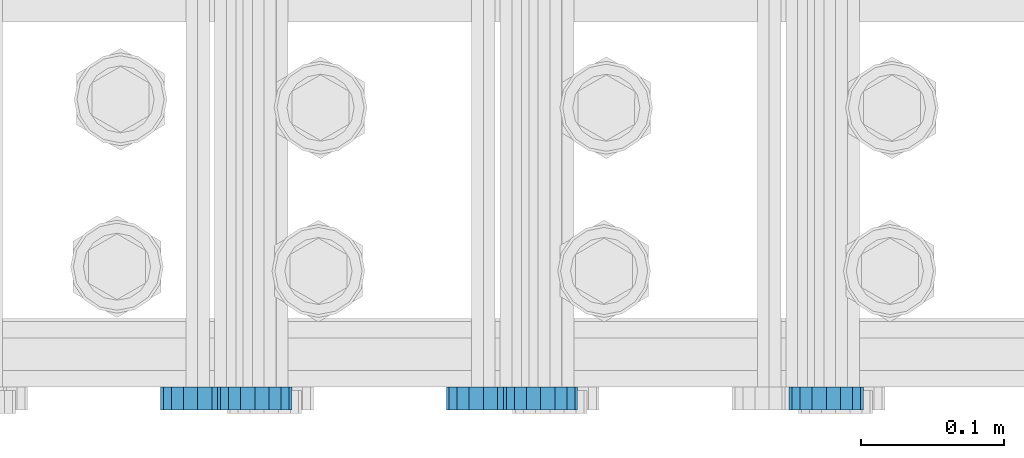
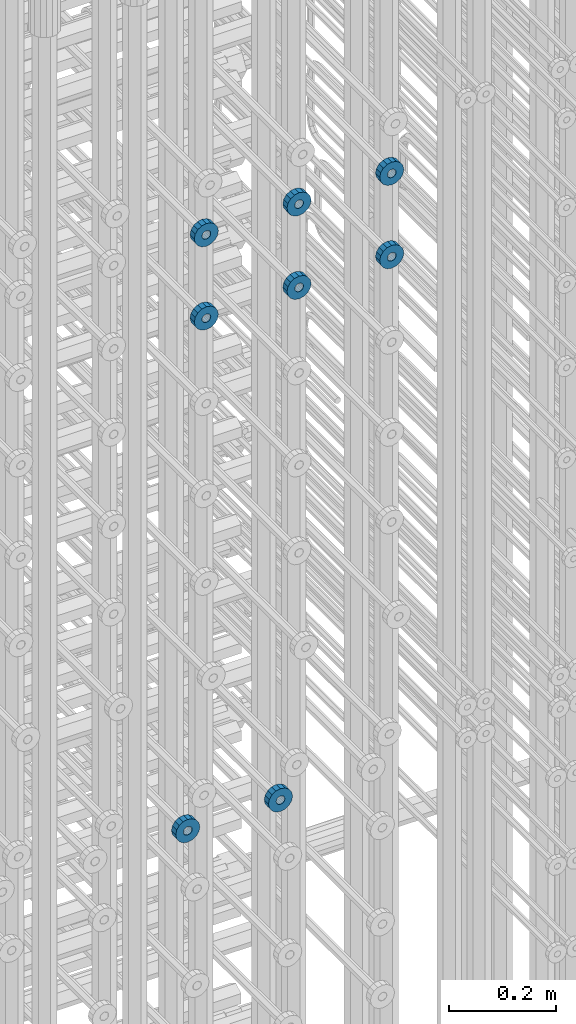
# One storey, part 123 of 177: 8 beams.
"""IFC2X3 building model written with IfcOpenShell, lengths in millimetres."""

from ifc_helpers import new_model, si_unit, frame, origin_with_axes, place, context, subcontext, project, spatial, faceted_brep, material, type_object, element, save


model = new_model("IFC2X3")

# Units and contexts
model_context_1 = context("Model", 3, precision=1e-05, world=origin_with_axes())
model_context_2 = context("Model", 3, precision=1e-05, world=origin_with_axes())
body_context = subcontext(model_context_2, "Body", "Model", "MODEL_VIEW")
ifc_project = project(units=[si_unit("LENGTHUNIT", "METRE", prefix="MILLI"), si_unit("AREAUNIT", "SQUARE_METRE"), si_unit("VOLUMEUNIT", "CUBIC_METRE"), si_unit("MASSUNIT", "GRAM", prefix="KILO"), si_unit("TIMEUNIT", "SECOND"), si_unit("PLANEANGLEUNIT", "RADIAN"), si_unit("SOLIDANGLEUNIT", "STERADIAN"), si_unit("THERMODYNAMICTEMPERATUREUNIT", "DEGREE_CELSIUS"), si_unit("LUMINOUSINTENSITYUNIT", "LUMEN")], contexts=[model_context_1])

# Site, building, storey
site_placement = place(None, origin_with_axes())
site = spatial("IfcSite", under=ifc_project, at=site_placement, CompositionType="ELEMENT")
building_placement = place(site_placement, origin_with_axes())
building = spatial("IfcBuilding", under=site, at=building_placement, Name="Undefined", CompositionType="ELEMENT")
storey_placement = place(building_placement, origin_with_axes())
storey = spatial("IfcBuildingStorey", under=building, at=storey_placement, Name="Undefined", CompositionType="ELEMENT", Elevation=0.0)

# Beams
ifc_material = material(Name="STEEL/Steel_Undefined")
beam_type = type_object("IfcBeamType", PredefinedType="NOTDEFINED")
beam_1_placement = place(storey_placement, frame((2031089.49847313, 6205075.98588033, 20799.986811442), z_axis=(0.0, 0.0, -1.0), x_axis=(0.0, -1.0, 0.0)))
element("IfcBeam", 1, at=beam_1_placement, inside=storey, type_object=beam_type, material=ifc_material, context=body_context, shape_type="Brep", body=[
    faceted_brep([(0.0, -9.5, 0.0), (0.0, -8.77685555908829, 3.63549260746731), (16.0, -8.77685555908829, 3.63549260746731), (16.0, -9.5, 0.0), (0.0, -6.71751442085952, 6.71751442127061), (16.0, -6.71751442085952, 6.71751442127061), (0.0, -3.63549260701984, 8.77685555885546), (16.0, -3.63549260701984, 8.77685555885546), (-2.02452244836415e-12, 0.0, 9.5), (16.0, 0.0, 9.5), (0.0, 3.63549260701984, 8.77685555885546), (16.0, 3.63549260701984, 8.77685555885546), (0.0, 6.71751442085952, 6.71751442127061), (16.0, 6.71751442085952, 6.71751442127061), (0.0, 8.77685555908829, 3.63549260746731), (16.0, 8.77685555908829, 3.63549260746731), (0.0, 9.5, 0.0), (16.0, 9.5, 0.0), (0.0, 8.77685555908829, -3.63549260746731), (16.0, 8.77685555908829, -3.63549260746731), (0.0, 6.71751442085952, -6.71751442127061), (16.0, 6.71751442085952, -6.71751442127061), (0.0, 3.63549260701984, -8.77685555885546), (16.0, 3.63549260701984, -8.77685555885546), (2.02452244836415e-12, -3.69149155687865e-15, -9.5), (16.0, 0.0, -9.5), (0.0, -3.63549260701984, -8.77685555885546), (16.0, -3.63549260701984, -8.77685555885546), (0.0, -6.71751442085952, -6.71751442127061), (16.0, -6.71751442085952, -6.71751442127061), (0.0, -8.77685555908829, -3.63549260746731), (16.0, -8.77685555908829, -3.63549260746731), (0.0, -26.0, 0.0), (0.0, -24.0208678450435, -9.94976924149159), (16.0, -24.0208678450435, -9.94976924149159), (16.0, -26.0, 0.0), (0.0, -18.3847763109952, -18.3847763108497), (16.0, -18.3847763109952, -18.3847763108497), (0.0, -9.94976924173534, -24.0208678452946), (16.0, -9.94976924173534, -24.0208678452946), (0.0, 0.0, -26.0), (16.0, 0.0, -26.0), (0.0, 9.94976924173534, -24.0208678452946), (16.0, 9.94976924173534, -24.0208678452946), (0.0, 18.3847763109952, -18.3847763108497), (16.0, 18.3847763109952, -18.3847763108497), (0.0, 24.0208678450435, -9.94976924149159), (16.0, 24.0208678450435, -9.94976924149159), (0.0, 26.0, 0.0), (16.0, 26.0, 0.0), (0.0, 24.0208678450435, 9.94976924149159), (16.0, 24.0208678450435, 9.94976924149159), (0.0, 18.3847763109952, 18.3847763108497), (16.0, 18.3847763109952, 18.3847763108497), (0.0, 9.94976924173534, 24.0208678452946), (16.0, 9.94976924173534, 24.0208678452946), (0.0, 0.0, 26.0), (16.0, 0.0, 26.0), (0.0, -9.94976924173534, 24.0208678452946), (16.0, -9.94976924173534, 24.0208678452946), (0.0, -18.3847763109952, 18.3847763108497), (16.0, -18.3847763109952, 18.3847763108497), (0.0, -24.0208678450435, 9.94976924149159), (16.0, -24.0208678450435, 9.94976924149159)], [[[0, 1, 2, 3]], [[1, 4, 5, 2]], [[4, 6, 7, 5]], [[6, 8, 9, 7]], [[8, 10, 11, 9]], [[10, 12, 13, 11]], [[12, 14, 15, 13]], [[14, 16, 17, 15]], [[16, 18, 19, 17]], [[18, 20, 21, 19]], [[20, 22, 23, 21]], [[22, 24, 25, 23]], [[24, 26, 27, 25]], [[26, 28, 29, 27]], [[28, 30, 31, 29]], [[30, 0, 3, 31]], [[32, 33, 34, 35]], [[33, 36, 37, 34]], [[36, 38, 39, 37]], [[38, 40, 41, 39]], [[40, 42, 43, 41]], [[42, 44, 45, 43]], [[44, 46, 47, 45]], [[46, 48, 49, 47]], [[48, 50, 51, 49]], [[50, 52, 53, 51]], [[52, 54, 55, 53]], [[54, 56, 57, 55]], [[56, 58, 59, 57]], [[58, 60, 61, 59]], [[60, 62, 63, 61]], [[62, 32, 35, 63]], [[37, 39, 41, 43, 45, 47, 49, 51, 53, 55, 57, 59, 61, 63, 35, 34], [5, 7, 9, 11, 13, 15, 17, 19, 21, 23, 25, 27, 29, 31, 3, 2]], [[62, 60, 58, 56, 54, 52, 50, 48, 46, 44, 42, 40, 38, 36, 33, 32], [30, 28, 26, 24, 22, 20, 18, 16, 14, 12, 10, 8, 6, 4, 1, 0]]]),
])
beam_2_placement = place(storey_placement, frame((2030889.49847313, 6205075.98588033, 20799.986811442), z_axis=(0.0, 0.0, -1.0), x_axis=(0.0, -1.0, 0.0)))
element("IfcBeam", 2, at=beam_2_placement, inside=storey, type_object=beam_type, material=ifc_material, context=body_context, shape_type="Brep", body=[
    faceted_brep([(0.0, -9.5, 0.0), (0.0, -8.77685555908829, 3.63549260746731), (16.0, -8.77685555908829, 3.63549260746731), (16.0, -9.5, 0.0), (0.0, -6.71751442085952, 6.71751442127061), (16.0, -6.71751442085952, 6.71751442127061), (0.0, -3.63549260701984, 8.77685555885546), (16.0, -3.63549260701984, 8.77685555885546), (-2.02452244836415e-12, 0.0, 9.5), (16.0, 0.0, 9.5), (0.0, 3.63549260701984, 8.77685555885546), (16.0, 3.63549260701984, 8.77685555885546), (0.0, 6.71751442085952, 6.71751442127061), (16.0, 6.71751442085952, 6.71751442127061), (0.0, 8.77685555908829, 3.63549260746731), (16.0, 8.77685555908829, 3.63549260746731), (0.0, 9.5, 0.0), (16.0, 9.5, 0.0), (0.0, 8.77685555908829, -3.63549260746731), (16.0, 8.77685555908829, -3.63549260746731), (0.0, 6.71751442085952, -6.71751442127061), (16.0, 6.71751442085952, -6.71751442127061), (0.0, 3.63549260701984, -8.77685555885546), (16.0, 3.63549260701984, -8.77685555885546), (2.02452244836415e-12, -3.69149155687865e-15, -9.5), (16.0, 0.0, -9.5), (0.0, -3.63549260701984, -8.77685555885546), (16.0, -3.63549260701984, -8.77685555885546), (0.0, -6.71751442085952, -6.71751442127061), (16.0, -6.71751442085952, -6.71751442127061), (0.0, -8.77685555908829, -3.63549260746731), (16.0, -8.77685555908829, -3.63549260746731), (0.0, -26.0, 0.0), (0.0, -24.0208678450435, -9.94976924149159), (16.0, -24.0208678450435, -9.94976924149159), (16.0, -26.0, 0.0), (0.0, -18.3847763109952, -18.3847763108497), (16.0, -18.3847763109952, -18.3847763108497), (0.0, -9.94976924173534, -24.0208678452946), (16.0, -9.94976924173534, -24.0208678452946), (0.0, 0.0, -26.0), (16.0, 0.0, -26.0), (0.0, 9.94976924173534, -24.0208678452946), (16.0, 9.94976924173534, -24.0208678452946), (0.0, 18.3847763109952, -18.3847763108497), (16.0, 18.3847763109952, -18.3847763108497), (0.0, 24.0208678450435, -9.94976924149159), (16.0, 24.0208678450435, -9.94976924149159), (0.0, 26.0, 0.0), (16.0, 26.0, 0.0), (0.0, 24.0208678450435, 9.94976924149159), (16.0, 24.0208678450435, 9.94976924149159), (0.0, 18.3847763109952, 18.3847763108497), (16.0, 18.3847763109952, 18.3847763108497), (0.0, 9.94976924173534, 24.0208678452946), (16.0, 9.94976924173534, 24.0208678452946), (0.0, 0.0, 26.0), (16.0, 0.0, 26.0), (0.0, -9.94976924173534, 24.0208678452946), (16.0, -9.94976924173534, 24.0208678452946), (0.0, -18.3847763109952, 18.3847763108497), (16.0, -18.3847763109952, 18.3847763108497), (0.0, -24.0208678450435, 9.94976924149159), (16.0, -24.0208678450435, 9.94976924149159)], [[[0, 1, 2, 3]], [[1, 4, 5, 2]], [[4, 6, 7, 5]], [[6, 8, 9, 7]], [[8, 10, 11, 9]], [[10, 12, 13, 11]], [[12, 14, 15, 13]], [[14, 16, 17, 15]], [[16, 18, 19, 17]], [[18, 20, 21, 19]], [[20, 22, 23, 21]], [[22, 24, 25, 23]], [[24, 26, 27, 25]], [[26, 28, 29, 27]], [[28, 30, 31, 29]], [[30, 0, 3, 31]], [[32, 33, 34, 35]], [[33, 36, 37, 34]], [[36, 38, 39, 37]], [[38, 40, 41, 39]], [[40, 42, 43, 41]], [[42, 44, 45, 43]], [[44, 46, 47, 45]], [[46, 48, 49, 47]], [[48, 50, 51, 49]], [[50, 52, 53, 51]], [[52, 54, 55, 53]], [[54, 56, 57, 55]], [[56, 58, 59, 57]], [[58, 60, 61, 59]], [[60, 62, 63, 61]], [[62, 32, 35, 63]], [[37, 39, 41, 43, 45, 47, 49, 51, 53, 55, 57, 59, 61, 63, 35, 34], [5, 7, 9, 11, 13, 15, 17, 19, 21, 23, 25, 27, 29, 31, 3, 2]], [[62, 60, 58, 56, 54, 52, 50, 48, 46, 44, 42, 40, 38, 36, 33, 32], [30, 28, 26, 24, 22, 20, 18, 16, 14, 12, 10, 8, 6, 4, 1, 0]]]),
])
beam_3_placement = place(storey_placement, frame((2031329.49847313, 6205075.98588636, 22144.9868126721), z_axis=(0.0, 0.0, -1.0), x_axis=(0.0, -1.0, 0.0)))
element("IfcBeam", 3, at=beam_3_placement, inside=storey, type_object=beam_type, material=ifc_material, context=body_context, shape_type="Brep", body=[
    faceted_brep([(0.0, -9.5, 0.0), (0.0, -8.77685555908829, 3.63549260746731), (16.0, -8.77685555908829, 3.63549260746731), (16.0, -9.5, 0.0), (0.0, -6.71751442085952, 6.71751442127061), (16.0, -6.71751442085952, 6.71751442127061), (0.0, -3.63549260701984, 8.77685555885546), (16.0, -3.63549260701984, 8.77685555885546), (-2.02452244836415e-12, 0.0, 9.5), (16.0, 0.0, 9.5), (0.0, 3.63549260701984, 8.77685555885546), (16.0, 3.63549260701984, 8.77685555885546), (0.0, 6.71751442085952, 6.71751442127061), (16.0, 6.71751442085952, 6.71751442127061), (0.0, 8.77685555908829, 3.63549260746731), (16.0, 8.77685555908829, 3.63549260746731), (0.0, 9.5, 0.0), (16.0, 9.5, 0.0), (0.0, 8.77685555908829, -3.63549260746731), (16.0, 8.77685555908829, -3.63549260746731), (0.0, 6.71751442085952, -6.71751442127061), (16.0, 6.71751442085952, -6.71751442127061), (0.0, 3.63549260701984, -8.77685555885546), (16.0, 3.63549260701984, -8.77685555885546), (2.02452244836415e-12, -3.69149155687865e-15, -9.5), (16.0, 0.0, -9.5), (0.0, -3.63549260701984, -8.77685555885546), (16.0, -3.63549260701984, -8.77685555885546), (0.0, -6.71751442085952, -6.71751442127061), (16.0, -6.71751442085952, -6.71751442127061), (0.0, -8.77685555908829, -3.63549260746731), (16.0, -8.77685555908829, -3.63549260746731), (0.0, -26.0, 0.0), (0.0, -24.0208678450435, -9.94976924149159), (16.0, -24.0208678450435, -9.94976924149159), (16.0, -26.0, 0.0), (0.0, -18.3847763109952, -18.3847763108497), (16.0, -18.3847763109952, -18.3847763108497), (0.0, -9.94976924173534, -24.0208678452946), (16.0, -9.94976924173534, -24.0208678452946), (0.0, 0.0, -26.0), (16.0, 0.0, -26.0), (0.0, 9.94976924173534, -24.0208678452946), (16.0, 9.94976924173534, -24.0208678452946), (0.0, 18.3847763109952, -18.3847763108497), (16.0, 18.3847763109952, -18.3847763108497), (0.0, 24.0208678450435, -9.94976924149159), (16.0, 24.0208678450435, -9.94976924149159), (0.0, 26.0, 0.0), (16.0, 26.0, 0.0), (0.0, 24.0208678450435, 9.94976924149159), (16.0, 24.0208678450435, 9.94976924149159), (0.0, 18.3847763109952, 18.3847763108497), (16.0, 18.3847763109952, 18.3847763108497), (0.0, 9.94976924173534, 24.0208678452946), (16.0, 9.94976924173534, 24.0208678452946), (0.0, 0.0, 26.0), (16.0, 0.0, 26.0), (0.0, -9.94976924173534, 24.0208678452946), (16.0, -9.94976924173534, 24.0208678452946), (0.0, -18.3847763109952, 18.3847763108497), (16.0, -18.3847763109952, 18.3847763108497), (0.0, -24.0208678450435, 9.94976924149159), (16.0, -24.0208678450435, 9.94976924149159)], [[[0, 1, 2, 3]], [[1, 4, 5, 2]], [[4, 6, 7, 5]], [[6, 8, 9, 7]], [[8, 10, 11, 9]], [[10, 12, 13, 11]], [[12, 14, 15, 13]], [[14, 16, 17, 15]], [[16, 18, 19, 17]], [[18, 20, 21, 19]], [[20, 22, 23, 21]], [[22, 24, 25, 23]], [[24, 26, 27, 25]], [[26, 28, 29, 27]], [[28, 30, 31, 29]], [[30, 0, 3, 31]], [[32, 33, 34, 35]], [[33, 36, 37, 34]], [[36, 38, 39, 37]], [[38, 40, 41, 39]], [[40, 42, 43, 41]], [[42, 44, 45, 43]], [[44, 46, 47, 45]], [[46, 48, 49, 47]], [[48, 50, 51, 49]], [[50, 52, 53, 51]], [[52, 54, 55, 53]], [[54, 56, 57, 55]], [[56, 58, 59, 57]], [[58, 60, 61, 59]], [[60, 62, 63, 61]], [[62, 32, 35, 63]], [[37, 39, 41, 43, 45, 47, 49, 51, 53, 55, 57, 59, 61, 63, 35, 34], [5, 7, 9, 11, 13, 15, 17, 19, 21, 23, 25, 27, 29, 31, 3, 2]], [[62, 60, 58, 56, 54, 52, 50, 48, 46, 44, 42, 40, 38, 36, 33, 32], [30, 28, 26, 24, 22, 20, 18, 16, 14, 12, 10, 8, 6, 4, 1, 0]]]),
])
beam_4_placement = place(storey_placement, frame((2031129.49847313, 6205075.98588636, 22144.9868126721), z_axis=(0.0, 0.0, -1.0), x_axis=(0.0, -1.0, 0.0)))
element("IfcBeam", 4, at=beam_4_placement, inside=storey, type_object=beam_type, material=ifc_material, context=body_context, shape_type="Brep", body=[
    faceted_brep([(0.0, -9.5, 0.0), (0.0, -8.77685555908829, 3.63549260746731), (16.0, -8.77685555908829, 3.63549260746731), (16.0, -9.5, 0.0), (0.0, -6.71751442085952, 6.71751442127061), (16.0, -6.71751442085952, 6.71751442127061), (0.0, -3.63549260701984, 8.77685555885546), (16.0, -3.63549260701984, 8.77685555885546), (-2.02452244836415e-12, 0.0, 9.5), (16.0, 0.0, 9.5), (0.0, 3.63549260701984, 8.77685555885546), (16.0, 3.63549260701984, 8.77685555885546), (0.0, 6.71751442085952, 6.71751442127061), (16.0, 6.71751442085952, 6.71751442127061), (0.0, 8.77685555908829, 3.63549260746731), (16.0, 8.77685555908829, 3.63549260746731), (0.0, 9.5, 0.0), (16.0, 9.5, 0.0), (0.0, 8.77685555908829, -3.63549260746731), (16.0, 8.77685555908829, -3.63549260746731), (0.0, 6.71751442085952, -6.71751442127061), (16.0, 6.71751442085952, -6.71751442127061), (0.0, 3.63549260701984, -8.77685555885546), (16.0, 3.63549260701984, -8.77685555885546), (2.02452244836415e-12, -3.69149155687865e-15, -9.5), (16.0, 0.0, -9.5), (0.0, -3.63549260701984, -8.77685555885546), (16.0, -3.63549260701984, -8.77685555885546), (0.0, -6.71751442085952, -6.71751442127061), (16.0, -6.71751442085952, -6.71751442127061), (0.0, -8.77685555908829, -3.63549260746731), (16.0, -8.77685555908829, -3.63549260746731), (0.0, -26.0, 0.0), (0.0, -24.0208678450435, -9.94976924149159), (16.0, -24.0208678450435, -9.94976924149159), (16.0, -26.0, 0.0), (0.0, -18.3847763109952, -18.3847763108497), (16.0, -18.3847763109952, -18.3847763108497), (0.0, -9.94976924173534, -24.0208678452946), (16.0, -9.94976924173534, -24.0208678452946), (0.0, 0.0, -26.0), (16.0, 0.0, -26.0), (0.0, 9.94976924173534, -24.0208678452946), (16.0, 9.94976924173534, -24.0208678452946), (0.0, 18.3847763109952, -18.3847763108497), (16.0, 18.3847763109952, -18.3847763108497), (0.0, 24.0208678450435, -9.94976924149159), (16.0, 24.0208678450435, -9.94976924149159), (0.0, 26.0, 0.0), (16.0, 26.0, 0.0), (0.0, 24.0208678450435, 9.94976924149159), (16.0, 24.0208678450435, 9.94976924149159), (0.0, 18.3847763109952, 18.3847763108497), (16.0, 18.3847763109952, 18.3847763108497), (0.0, 9.94976924173534, 24.0208678452946), (16.0, 9.94976924173534, 24.0208678452946), (0.0, 0.0, 26.0), (16.0, 0.0, 26.0), (0.0, -9.94976924173534, 24.0208678452946), (16.0, -9.94976924173534, 24.0208678452946), (0.0, -18.3847763109952, 18.3847763108497), (16.0, -18.3847763109952, 18.3847763108497), (0.0, -24.0208678450435, 9.94976924149159), (16.0, -24.0208678450435, 9.94976924149159)], [[[0, 1, 2, 3]], [[1, 4, 5, 2]], [[4, 6, 7, 5]], [[6, 8, 9, 7]], [[8, 10, 11, 9]], [[10, 12, 13, 11]], [[12, 14, 15, 13]], [[14, 16, 17, 15]], [[16, 18, 19, 17]], [[18, 20, 21, 19]], [[20, 22, 23, 21]], [[22, 24, 25, 23]], [[24, 26, 27, 25]], [[26, 28, 29, 27]], [[28, 30, 31, 29]], [[30, 0, 3, 31]], [[32, 33, 34, 35]], [[33, 36, 37, 34]], [[36, 38, 39, 37]], [[38, 40, 41, 39]], [[40, 42, 43, 41]], [[42, 44, 45, 43]], [[44, 46, 47, 45]], [[46, 48, 49, 47]], [[48, 50, 51, 49]], [[50, 52, 53, 51]], [[52, 54, 55, 53]], [[54, 56, 57, 55]], [[56, 58, 59, 57]], [[58, 60, 61, 59]], [[60, 62, 63, 61]], [[62, 32, 35, 63]], [[37, 39, 41, 43, 45, 47, 49, 51, 53, 55, 57, 59, 61, 63, 35, 34], [5, 7, 9, 11, 13, 15, 17, 19, 21, 23, 25, 27, 29, 31, 3, 2]], [[62, 60, 58, 56, 54, 52, 50, 48, 46, 44, 42, 40, 38, 36, 33, 32], [30, 28, 26, 24, 22, 20, 18, 16, 14, 12, 10, 8, 6, 4, 1, 0]]]),
])
beam_5_placement = place(storey_placement, frame((2030929.49847313, 6205075.98588636, 22144.9868126721), z_axis=(0.0, 0.0, -1.0), x_axis=(0.0, -1.0, 0.0)))
element("IfcBeam", 5, at=beam_5_placement, inside=storey, type_object=beam_type, material=ifc_material, context=body_context, shape_type="Brep", body=[
    faceted_brep([(0.0, -9.5, 0.0), (0.0, -8.77685555908829, 3.63549260746731), (16.0, -8.77685555908829, 3.63549260746731), (16.0, -9.5, 0.0), (0.0, -6.71751442085952, 6.71751442127061), (16.0, -6.71751442085952, 6.71751442127061), (0.0, -3.63549260701984, 8.77685555885546), (16.0, -3.63549260701984, 8.77685555885546), (-2.02452244836415e-12, 0.0, 9.5), (16.0, 0.0, 9.5), (0.0, 3.63549260701984, 8.77685555885546), (16.0, 3.63549260701984, 8.77685555885546), (0.0, 6.71751442085952, 6.71751442127061), (16.0, 6.71751442085952, 6.71751442127061), (0.0, 8.77685555908829, 3.63549260746731), (16.0, 8.77685555908829, 3.63549260746731), (0.0, 9.5, 0.0), (16.0, 9.5, 0.0), (0.0, 8.77685555908829, -3.63549260746731), (16.0, 8.77685555908829, -3.63549260746731), (0.0, 6.71751442085952, -6.71751442127061), (16.0, 6.71751442085952, -6.71751442127061), (0.0, 3.63549260701984, -8.77685555885546), (16.0, 3.63549260701984, -8.77685555885546), (2.02452244836415e-12, -3.69149155687865e-15, -9.5), (16.0, 0.0, -9.5), (0.0, -3.63549260701984, -8.77685555885546), (16.0, -3.63549260701984, -8.77685555885546), (0.0, -6.71751442085952, -6.71751442127061), (16.0, -6.71751442085952, -6.71751442127061), (0.0, -8.77685555908829, -3.63549260746731), (16.0, -8.77685555908829, -3.63549260746731), (0.0, -26.0, 0.0), (0.0, -24.0208678450435, -9.94976924149159), (16.0, -24.0208678450435, -9.94976924149159), (16.0, -26.0, 0.0), (0.0, -18.3847763109952, -18.3847763108497), (16.0, -18.3847763109952, -18.3847763108497), (0.0, -9.94976924173534, -24.0208678452946), (16.0, -9.94976924173534, -24.0208678452946), (0.0, 0.0, -26.0), (16.0, 0.0, -26.0), (0.0, 9.94976924173534, -24.0208678452946), (16.0, 9.94976924173534, -24.0208678452946), (0.0, 18.3847763109952, -18.3847763108497), (16.0, 18.3847763109952, -18.3847763108497), (0.0, 24.0208678450435, -9.94976924149159), (16.0, 24.0208678450435, -9.94976924149159), (0.0, 26.0, 0.0), (16.0, 26.0, 0.0), (0.0, 24.0208678450435, 9.94976924149159), (16.0, 24.0208678450435, 9.94976924149159), (0.0, 18.3847763109952, 18.3847763108497), (16.0, 18.3847763109952, 18.3847763108497), (0.0, 9.94976924173534, 24.0208678452946), (16.0, 9.94976924173534, 24.0208678452946), (0.0, 0.0, 26.0), (16.0, 0.0, 26.0), (0.0, -9.94976924173534, 24.0208678452946), (16.0, -9.94976924173534, 24.0208678452946), (0.0, -18.3847763109952, 18.3847763108497), (16.0, -18.3847763109952, 18.3847763108497), (0.0, -24.0208678450435, 9.94976924149159), (16.0, -24.0208678450435, 9.94976924149159)], [[[0, 1, 2, 3]], [[1, 4, 5, 2]], [[4, 6, 7, 5]], [[6, 8, 9, 7]], [[8, 10, 11, 9]], [[10, 12, 13, 11]], [[12, 14, 15, 13]], [[14, 16, 17, 15]], [[16, 18, 19, 17]], [[18, 20, 21, 19]], [[20, 22, 23, 21]], [[22, 24, 25, 23]], [[24, 26, 27, 25]], [[26, 28, 29, 27]], [[28, 30, 31, 29]], [[30, 0, 3, 31]], [[32, 33, 34, 35]], [[33, 36, 37, 34]], [[36, 38, 39, 37]], [[38, 40, 41, 39]], [[40, 42, 43, 41]], [[42, 44, 45, 43]], [[44, 46, 47, 45]], [[46, 48, 49, 47]], [[48, 50, 51, 49]], [[50, 52, 53, 51]], [[52, 54, 55, 53]], [[54, 56, 57, 55]], [[56, 58, 59, 57]], [[58, 60, 61, 59]], [[60, 62, 63, 61]], [[62, 32, 35, 63]], [[37, 39, 41, 43, 45, 47, 49, 51, 53, 55, 57, 59, 61, 63, 35, 34], [5, 7, 9, 11, 13, 15, 17, 19, 21, 23, 25, 27, 29, 31, 3, 2]], [[62, 60, 58, 56, 54, 52, 50, 48, 46, 44, 42, 40, 38, 36, 33, 32], [30, 28, 26, 24, 22, 20, 18, 16, 14, 12, 10, 8, 6, 4, 1, 0]]]),
])
beam_6_placement = place(storey_placement, frame((2031329.49847313, 6205075.98588032, 21954.9868114202), z_axis=(0.0, 0.0, -1.0), x_axis=(0.0, -1.0, 0.0)))
element("IfcBeam", 6, at=beam_6_placement, inside=storey, type_object=beam_type, material=ifc_material, context=body_context, shape_type="Brep", body=[
    faceted_brep([(0.0, -9.5, 0.0), (0.0, -8.77685555908829, 3.63549260746731), (16.0, -8.77685555908829, 3.63549260746731), (16.0, -9.5, 0.0), (0.0, -6.71751442085952, 6.71751442127061), (16.0, -6.71751442085952, 6.71751442127061), (0.0, -3.63549260701984, 8.77685555885546), (16.0, -3.63549260701984, 8.77685555885546), (-2.02452244836415e-12, 0.0, 9.5), (16.0, 0.0, 9.5), (0.0, 3.63549260701984, 8.77685555885546), (16.0, 3.63549260701984, 8.77685555885546), (0.0, 6.71751442085952, 6.71751442127061), (16.0, 6.71751442085952, 6.71751442127061), (0.0, 8.77685555908829, 3.63549260746731), (16.0, 8.77685555908829, 3.63549260746731), (0.0, 9.5, 0.0), (16.0, 9.5, 0.0), (0.0, 8.77685555908829, -3.63549260746731), (16.0, 8.77685555908829, -3.63549260746731), (0.0, 6.71751442085952, -6.71751442127061), (16.0, 6.71751442085952, -6.71751442127061), (0.0, 3.63549260701984, -8.77685555885546), (16.0, 3.63549260701984, -8.77685555885546), (2.02452244836415e-12, -3.69149155687865e-15, -9.5), (16.0, 0.0, -9.5), (0.0, -3.63549260701984, -8.77685555885546), (16.0, -3.63549260701984, -8.77685555885546), (0.0, -6.71751442085952, -6.71751442127061), (16.0, -6.71751442085952, -6.71751442127061), (0.0, -8.77685555908829, -3.63549260746731), (16.0, -8.77685555908829, -3.63549260746731), (0.0, -26.0, 0.0), (0.0, -24.0208678450435, -9.94976924149159), (16.0, -24.0208678450435, -9.94976924149159), (16.0, -26.0, 0.0), (0.0, -18.3847763109952, -18.3847763108497), (16.0, -18.3847763109952, -18.3847763108497), (0.0, -9.94976924173534, -24.0208678452946), (16.0, -9.94976924173534, -24.0208678452946), (0.0, 0.0, -26.0), (16.0, 0.0, -26.0), (0.0, 9.94976924173534, -24.0208678452946), (16.0, 9.94976924173534, -24.0208678452946), (0.0, 18.3847763109952, -18.3847763108497), (16.0, 18.3847763109952, -18.3847763108497), (0.0, 24.0208678450435, -9.94976924149159), (16.0, 24.0208678450435, -9.94976924149159), (0.0, 26.0, 0.0), (16.0, 26.0, 0.0), (0.0, 24.0208678450435, 9.94976924149159), (16.0, 24.0208678450435, 9.94976924149159), (0.0, 18.3847763109952, 18.3847763108497), (16.0, 18.3847763109952, 18.3847763108497), (0.0, 9.94976924173534, 24.0208678452946), (16.0, 9.94976924173534, 24.0208678452946), (0.0, 0.0, 26.0), (16.0, 0.0, 26.0), (0.0, -9.94976924173534, 24.0208678452946), (16.0, -9.94976924173534, 24.0208678452946), (0.0, -18.3847763109952, 18.3847763108497), (16.0, -18.3847763109952, 18.3847763108497), (0.0, -24.0208678450435, 9.94976924149159), (16.0, -24.0208678450435, 9.94976924149159)], [[[0, 1, 2, 3]], [[1, 4, 5, 2]], [[4, 6, 7, 5]], [[6, 8, 9, 7]], [[8, 10, 11, 9]], [[10, 12, 13, 11]], [[12, 14, 15, 13]], [[14, 16, 17, 15]], [[16, 18, 19, 17]], [[18, 20, 21, 19]], [[20, 22, 23, 21]], [[22, 24, 25, 23]], [[24, 26, 27, 25]], [[26, 28, 29, 27]], [[28, 30, 31, 29]], [[30, 0, 3, 31]], [[32, 33, 34, 35]], [[33, 36, 37, 34]], [[36, 38, 39, 37]], [[38, 40, 41, 39]], [[40, 42, 43, 41]], [[42, 44, 45, 43]], [[44, 46, 47, 45]], [[46, 48, 49, 47]], [[48, 50, 51, 49]], [[50, 52, 53, 51]], [[52, 54, 55, 53]], [[54, 56, 57, 55]], [[56, 58, 59, 57]], [[58, 60, 61, 59]], [[60, 62, 63, 61]], [[62, 32, 35, 63]], [[37, 39, 41, 43, 45, 47, 49, 51, 53, 55, 57, 59, 61, 63, 35, 34], [5, 7, 9, 11, 13, 15, 17, 19, 21, 23, 25, 27, 29, 31, 3, 2]], [[62, 60, 58, 56, 54, 52, 50, 48, 46, 44, 42, 40, 38, 36, 33, 32], [30, 28, 26, 24, 22, 20, 18, 16, 14, 12, 10, 8, 6, 4, 1, 0]]]),
])
beam_7_placement = place(storey_placement, frame((2031129.49847313, 6205075.98588032, 21954.9868114202), z_axis=(0.0, 0.0, -1.0), x_axis=(0.0, -1.0, 0.0)))
element("IfcBeam", 7, at=beam_7_placement, inside=storey, type_object=beam_type, material=ifc_material, context=body_context, shape_type="Brep", body=[
    faceted_brep([(0.0, -9.5, 0.0), (0.0, -8.77685555908829, 3.63549260746731), (16.0, -8.77685555908829, 3.63549260746731), (16.0, -9.5, 0.0), (0.0, -6.71751442085952, 6.71751442127061), (16.0, -6.71751442085952, 6.71751442127061), (0.0, -3.63549260701984, 8.77685555885546), (16.0, -3.63549260701984, 8.77685555885546), (-2.02452244836415e-12, 0.0, 9.5), (16.0, 0.0, 9.5), (0.0, 3.63549260701984, 8.77685555885546), (16.0, 3.63549260701984, 8.77685555885546), (0.0, 6.71751442085952, 6.71751442127061), (16.0, 6.71751442085952, 6.71751442127061), (0.0, 8.77685555908829, 3.63549260746731), (16.0, 8.77685555908829, 3.63549260746731), (0.0, 9.5, 0.0), (16.0, 9.5, 0.0), (0.0, 8.77685555908829, -3.63549260746731), (16.0, 8.77685555908829, -3.63549260746731), (0.0, 6.71751442085952, -6.71751442127061), (16.0, 6.71751442085952, -6.71751442127061), (0.0, 3.63549260701984, -8.77685555885546), (16.0, 3.63549260701984, -8.77685555885546), (2.02452244836415e-12, -3.69149155687865e-15, -9.5), (16.0, 0.0, -9.5), (0.0, -3.63549260701984, -8.77685555885546), (16.0, -3.63549260701984, -8.77685555885546), (0.0, -6.71751442085952, -6.71751442127061), (16.0, -6.71751442085952, -6.71751442127061), (0.0, -8.77685555908829, -3.63549260746731), (16.0, -8.77685555908829, -3.63549260746731), (0.0, -26.0, 0.0), (0.0, -24.0208678450435, -9.94976924149159), (16.0, -24.0208678450435, -9.94976924149159), (16.0, -26.0, 0.0), (0.0, -18.3847763109952, -18.3847763108497), (16.0, -18.3847763109952, -18.3847763108497), (0.0, -9.94976924173534, -24.0208678452946), (16.0, -9.94976924173534, -24.0208678452946), (0.0, 0.0, -26.0), (16.0, 0.0, -26.0), (0.0, 9.94976924173534, -24.0208678452946), (16.0, 9.94976924173534, -24.0208678452946), (0.0, 18.3847763109952, -18.3847763108497), (16.0, 18.3847763109952, -18.3847763108497), (0.0, 24.0208678450435, -9.94976924149159), (16.0, 24.0208678450435, -9.94976924149159), (0.0, 26.0, 0.0), (16.0, 26.0, 0.0), (0.0, 24.0208678450435, 9.94976924149159), (16.0, 24.0208678450435, 9.94976924149159), (0.0, 18.3847763109952, 18.3847763108497), (16.0, 18.3847763109952, 18.3847763108497), (0.0, 9.94976924173534, 24.0208678452946), (16.0, 9.94976924173534, 24.0208678452946), (0.0, 0.0, 26.0), (16.0, 0.0, 26.0), (0.0, -9.94976924173534, 24.0208678452946), (16.0, -9.94976924173534, 24.0208678452946), (0.0, -18.3847763109952, 18.3847763108497), (16.0, -18.3847763109952, 18.3847763108497), (0.0, -24.0208678450435, 9.94976924149159), (16.0, -24.0208678450435, 9.94976924149159)], [[[0, 1, 2, 3]], [[1, 4, 5, 2]], [[4, 6, 7, 5]], [[6, 8, 9, 7]], [[8, 10, 11, 9]], [[10, 12, 13, 11]], [[12, 14, 15, 13]], [[14, 16, 17, 15]], [[16, 18, 19, 17]], [[18, 20, 21, 19]], [[20, 22, 23, 21]], [[22, 24, 25, 23]], [[24, 26, 27, 25]], [[26, 28, 29, 27]], [[28, 30, 31, 29]], [[30, 0, 3, 31]], [[32, 33, 34, 35]], [[33, 36, 37, 34]], [[36, 38, 39, 37]], [[38, 40, 41, 39]], [[40, 42, 43, 41]], [[42, 44, 45, 43]], [[44, 46, 47, 45]], [[46, 48, 49, 47]], [[48, 50, 51, 49]], [[50, 52, 53, 51]], [[52, 54, 55, 53]], [[54, 56, 57, 55]], [[56, 58, 59, 57]], [[58, 60, 61, 59]], [[60, 62, 63, 61]], [[62, 32, 35, 63]], [[37, 39, 41, 43, 45, 47, 49, 51, 53, 55, 57, 59, 61, 63, 35, 34], [5, 7, 9, 11, 13, 15, 17, 19, 21, 23, 25, 27, 29, 31, 3, 2]], [[62, 60, 58, 56, 54, 52, 50, 48, 46, 44, 42, 40, 38, 36, 33, 32], [30, 28, 26, 24, 22, 20, 18, 16, 14, 12, 10, 8, 6, 4, 1, 0]]]),
])
beam_8_placement = place(storey_placement, frame((2030929.49847313, 6205075.98588032, 21954.9868114202), z_axis=(0.0, 0.0, -1.0), x_axis=(0.0, -1.0, 0.0)))
element("IfcBeam", 8, at=beam_8_placement, inside=storey, type_object=beam_type, material=ifc_material, context=body_context, shape_type="Brep", body=[
    faceted_brep([(0.0, -9.5, 0.0), (0.0, -8.77685555908829, 3.63549260746731), (16.0, -8.77685555908829, 3.63549260746731), (16.0, -9.5, 0.0), (0.0, -6.71751442085952, 6.71751442127061), (16.0, -6.71751442085952, 6.71751442127061), (0.0, -3.63549260701984, 8.77685555885546), (16.0, -3.63549260701984, 8.77685555885546), (-2.02452244836415e-12, 0.0, 9.5), (16.0, 0.0, 9.5), (0.0, 3.63549260701984, 8.77685555885546), (16.0, 3.63549260701984, 8.77685555885546), (0.0, 6.71751442085952, 6.71751442127061), (16.0, 6.71751442085952, 6.71751442127061), (0.0, 8.77685555908829, 3.63549260746731), (16.0, 8.77685555908829, 3.63549260746731), (0.0, 9.5, 0.0), (16.0, 9.5, 0.0), (0.0, 8.77685555908829, -3.63549260746731), (16.0, 8.77685555908829, -3.63549260746731), (0.0, 6.71751442085952, -6.71751442127061), (16.0, 6.71751442085952, -6.71751442127061), (0.0, 3.63549260701984, -8.77685555885546), (16.0, 3.63549260701984, -8.77685555885546), (2.02452244836415e-12, -3.69149155687865e-15, -9.5), (16.0, 0.0, -9.5), (0.0, -3.63549260701984, -8.77685555885546), (16.0, -3.63549260701984, -8.77685555885546), (0.0, -6.71751442085952, -6.71751442127061), (16.0, -6.71751442085952, -6.71751442127061), (0.0, -8.77685555908829, -3.63549260746731), (16.0, -8.77685555908829, -3.63549260746731), (0.0, -26.0, 0.0), (0.0, -24.0208678450435, -9.94976924149159), (16.0, -24.0208678450435, -9.94976924149159), (16.0, -26.0, 0.0), (0.0, -18.3847763109952, -18.3847763108497), (16.0, -18.3847763109952, -18.3847763108497), (0.0, -9.94976924173534, -24.0208678452946), (16.0, -9.94976924173534, -24.0208678452946), (0.0, 0.0, -26.0), (16.0, 0.0, -26.0), (0.0, 9.94976924173534, -24.0208678452946), (16.0, 9.94976924173534, -24.0208678452946), (0.0, 18.3847763109952, -18.3847763108497), (16.0, 18.3847763109952, -18.3847763108497), (0.0, 24.0208678450435, -9.94976924149159), (16.0, 24.0208678450435, -9.94976924149159), (0.0, 26.0, 0.0), (16.0, 26.0, 0.0), (0.0, 24.0208678450435, 9.94976924149159), (16.0, 24.0208678450435, 9.94976924149159), (0.0, 18.3847763109952, 18.3847763108497), (16.0, 18.3847763109952, 18.3847763108497), (0.0, 9.94976924173534, 24.0208678452946), (16.0, 9.94976924173534, 24.0208678452946), (0.0, 0.0, 26.0), (16.0, 0.0, 26.0), (0.0, -9.94976924173534, 24.0208678452946), (16.0, -9.94976924173534, 24.0208678452946), (0.0, -18.3847763109952, 18.3847763108497), (16.0, -18.3847763109952, 18.3847763108497), (0.0, -24.0208678450435, 9.94976924149159), (16.0, -24.0208678450435, 9.94976924149159)], [[[0, 1, 2, 3]], [[1, 4, 5, 2]], [[4, 6, 7, 5]], [[6, 8, 9, 7]], [[8, 10, 11, 9]], [[10, 12, 13, 11]], [[12, 14, 15, 13]], [[14, 16, 17, 15]], [[16, 18, 19, 17]], [[18, 20, 21, 19]], [[20, 22, 23, 21]], [[22, 24, 25, 23]], [[24, 26, 27, 25]], [[26, 28, 29, 27]], [[28, 30, 31, 29]], [[30, 0, 3, 31]], [[32, 33, 34, 35]], [[33, 36, 37, 34]], [[36, 38, 39, 37]], [[38, 40, 41, 39]], [[40, 42, 43, 41]], [[42, 44, 45, 43]], [[44, 46, 47, 45]], [[46, 48, 49, 47]], [[48, 50, 51, 49]], [[50, 52, 53, 51]], [[52, 54, 55, 53]], [[54, 56, 57, 55]], [[56, 58, 59, 57]], [[58, 60, 61, 59]], [[60, 62, 63, 61]], [[62, 32, 35, 63]], [[37, 39, 41, 43, 45, 47, 49, 51, 53, 55, 57, 59, 61, 63, 35, 34], [5, 7, 9, 11, 13, 15, 17, 19, 21, 23, 25, 27, 29, 31, 3, 2]], [[62, 60, 58, 56, 54, 52, 50, 48, 46, 44, 42, 40, 38, 36, 33, 32], [30, 28, 26, 24, 22, 20, 18, 16, 14, 12, 10, 8, 6, 4, 1, 0]]]),
])

save(model, "model.ifc")
